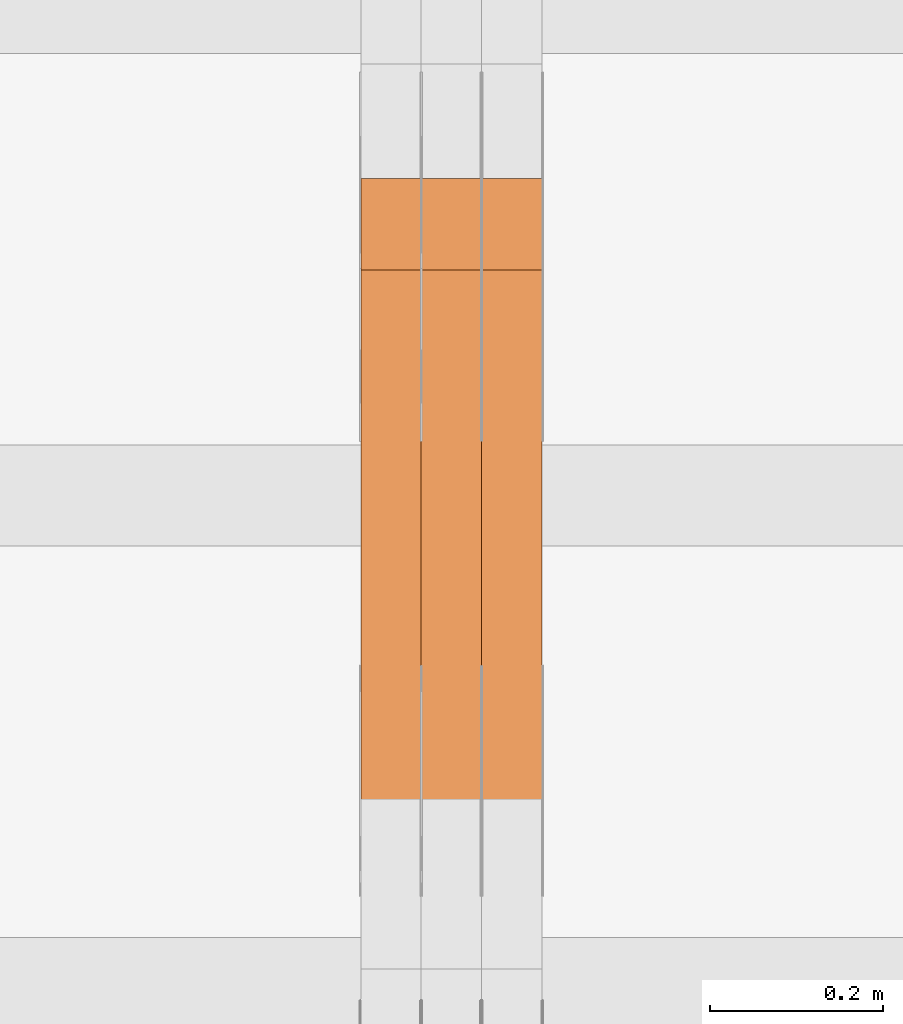
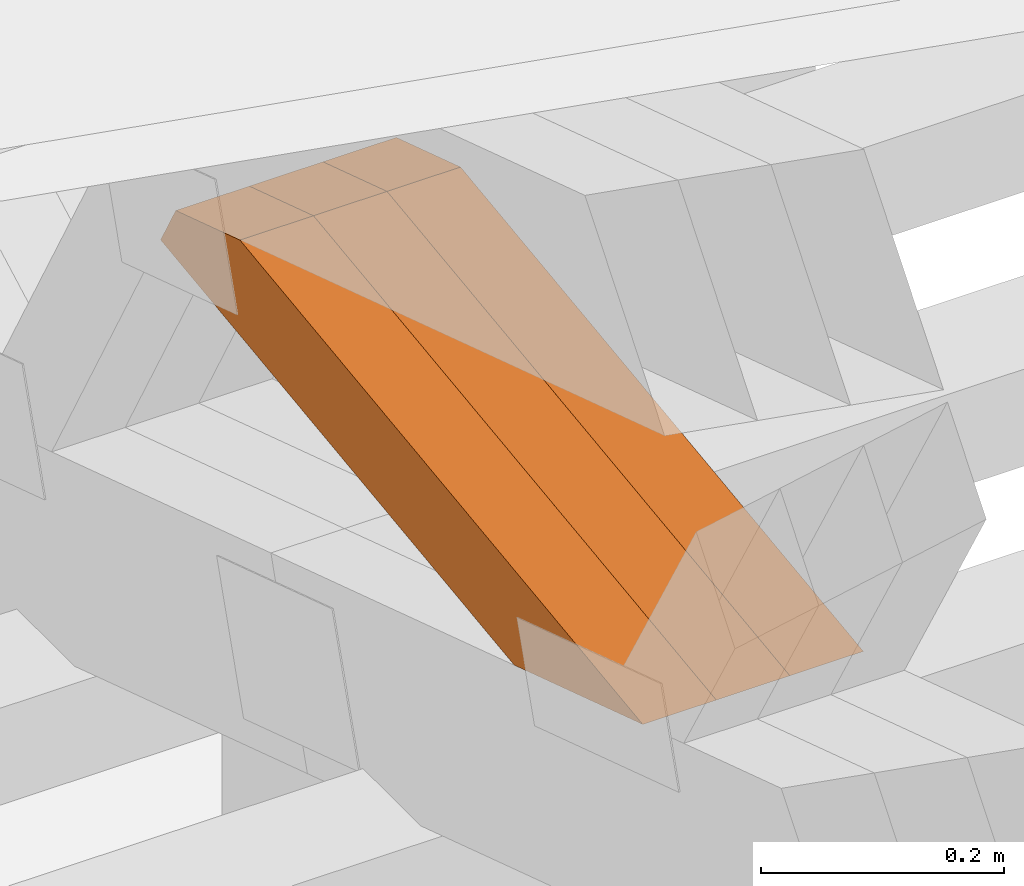
# One storey, part 305 of 385: 3 proxies.
"""IFC2X3 building model written with IfcOpenShell, lengths in millimetres."""

from ifc_helpers import new_model, entity, si_unit, converted_unit, derived_unit, direction, frame, origin, place, context, subcontext, project, spatial, polyline, outline, extrude, source, transform, mapped, material, type_object, type_shapes, element, save


model = new_model("IFC2X3")

# Units and contexts
model_context = context("Model", 3, precision=0.01, world=origin(), true_north=direction((6.12303176911189e-17, 1.0)))
body_context = subcontext(model_context, "Body", "Model", "MODEL_VIEW")
ifc_project = project(units=[si_unit("LENGTHUNIT", "METRE", prefix="MILLI"), si_unit("AREAUNIT", "SQUARE_METRE"), si_unit("VOLUMEUNIT", "CUBIC_METRE"), converted_unit("PLANEANGLEUNIT", "DEGREE", entity("IfcRatioMeasure", 0.0174532925199433), si_unit("PLANEANGLEUNIT", "RADIAN"), dimensions=[0, 0, 0, 0, 0, 0, 0]), si_unit("MASSUNIT", "GRAM", prefix="KILO"), derived_unit("MASSDENSITYUNIT", [(si_unit("MASSUNIT", "GRAM", prefix="KILO"), 1), (si_unit("LENGTHUNIT", "METRE"), -3)]), si_unit("TIMEUNIT", "SECOND"), si_unit("FREQUENCYUNIT", "HERTZ"), si_unit("THERMODYNAMICTEMPERATUREUNIT", "DEGREE_CELSIUS"), derived_unit("THERMALTRANSMITTANCEUNIT", [(si_unit("MASSUNIT", "GRAM", prefix="KILO"), 1), (si_unit("THERMODYNAMICTEMPERATUREUNIT", "KELVIN"), -1), (si_unit("TIMEUNIT", "SECOND"), -3)]), derived_unit("VOLUMETRICFLOWRATEUNIT", [(si_unit("LENGTHUNIT", "METRE"), 3), (si_unit("TIMEUNIT", "SECOND"), -1)]), si_unit("ELECTRICCURRENTUNIT", "AMPERE"), si_unit("ELECTRICVOLTAGEUNIT", "VOLT"), si_unit("POWERUNIT", "WATT"), si_unit("FORCEUNIT", "NEWTON", prefix="KILO"), si_unit("ILLUMINANCEUNIT", "LUX"), si_unit("LUMINOUSFLUXUNIT", "LUMEN"), si_unit("LUMINOUSINTENSITYUNIT", "CANDELA"), derived_unit("USERDEFINED", [(si_unit("MASSUNIT", "GRAM", prefix="KILO"), -1), (si_unit("LENGTHUNIT", "METRE"), -2), (si_unit("TIMEUNIT", "SECOND"), 3), (si_unit("LUMINOUSFLUXUNIT", "LUMEN"), 1)]), derived_unit("LINEARVELOCITYUNIT", [(si_unit("LENGTHUNIT", "METRE"), 1), (si_unit("TIMEUNIT", "SECOND"), -1)]), si_unit("PRESSUREUNIT", "PASCAL"), derived_unit("USERDEFINED", [(si_unit("LENGTHUNIT", "METRE"), -2), (si_unit("MASSUNIT", "GRAM", prefix="KILO"), 1), (si_unit("TIMEUNIT", "SECOND"), -2)])], contexts=[model_context])

# Site, building, storey
site_placement = place(None, origin())
site = spatial("IfcSite", under=ifc_project, at=site_placement, CompositionType="ELEMENT")
building_placement = place(site_placement, origin())
building = spatial("IfcBuilding", under=site, at=building_placement, CompositionType="ELEMENT")
storey_placement = place(building_placement, origin())
storey = spatial("IfcBuildingStorey", under=building, at=storey_placement, Name="Default", CompositionType="ELEMENT", Elevation=0.0)

# Proxies
ifc_material_1 = material(Name="IfcSurfaceStyle #532310")
building_element_proxy_type_1 = type_object("IfcBuildingElementProxyType", Name="T1-W6 532308", PredefinedType="NOTDEFINED", material=ifc_material_1)
shared_shape_1 = source(origin(), body_context, "Body", "SweptSolid", [
    extrude(outline(polyline([(-485.945461934772, -47.500204767976), (183.41906495488, -47.500204767976), (284.061400026172, 0.000179660053988773), (303.127757064591, 47.500114937949), (-284.66276011087, 47.500114937949), (-485.945461934772, -47.500204767976)])), frame((303.127970456024, 47.5001450766485, 0.0), z_axis=(0.0, 0.0, 1.0), x_axis=(-1.0, 0.0, 0.0)), (0.0, 0.0, 1.0), 70.0),
])
type_shapes(building_element_proxy_type_1, [shared_shape_1])
proxy_1_placement = place(building_placement, frame((45385.0, 19075.4826373647, 2770.72729201433), z_axis=(-1.0, 0.0, 0.0), x_axis=(0.0, -0.991969529622927, -0.126477082112413)))
element("IfcBuildingElementProxy", 1, at=proxy_1_placement, inside=storey, type_object=building_element_proxy_type_1, material=ifc_material_1, Name="T1-W6", context=body_context, shape_type="MappedRepresentation", body=[
    mapped(shared_shape_1, transform((0.0, 0.0, 0.0), scale=1.0)),
])
ifc_material_2 = material(Name="IfcSurfaceStyle #532244")
building_element_proxy_type_2 = type_object("IfcBuildingElementProxyType", Name="T1-W6 532242", PredefinedType="NOTDEFINED", material=ifc_material_2)
shared_shape_2 = source(origin(), body_context, "Body", "SweptSolid", [
    extrude(outline(polyline([(-485.945461934772, -47.500204767976), (183.41906495488, -47.500204767976), (284.061400026172, 0.000179660053988773), (303.127757064591, 47.500114937949), (-284.66276011087, 47.500114937949), (-485.945461934772, -47.500204767976)])), frame((303.127970456024, 47.5001450766485, 0.0), z_axis=(0.0, 0.0, 1.0), x_axis=(-1.0, 0.0, 0.0)), (0.0, 0.0, 1.0), 70.0),
])
type_shapes(building_element_proxy_type_2, [shared_shape_2])
proxy_2_placement = place(building_placement, frame((45315.0, 19075.4826373647, 2770.72729201433), z_axis=(-1.0, 0.0, 0.0), x_axis=(0.0, -0.991969529622927, -0.126477082112413)))
element("IfcBuildingElementProxy", 2, at=proxy_2_placement, inside=storey, type_object=building_element_proxy_type_2, material=ifc_material_2, Name="T1-W6", context=body_context, shape_type="MappedRepresentation", body=[
    mapped(shared_shape_2, transform((0.0, 0.0, 0.0), scale=1.0)),
])
ifc_material_3 = material(Name="IfcSurfaceStyle #532178")
building_element_proxy_type_3 = type_object("IfcBuildingElementProxyType", Name="T1-W6 532176", PredefinedType="NOTDEFINED", material=ifc_material_3)
shared_shape_3 = source(origin(), body_context, "Body", "SweptSolid", [
    extrude(outline(polyline([(-485.945461934772, -47.500204767976), (183.41906495488, -47.500204767976), (284.061400026172, 0.000179660053988773), (303.127757064591, 47.500114937949), (-284.66276011087, 47.500114937949), (-485.945461934772, -47.500204767976)])), frame((303.127970456024, 47.5001450766485, 0.0), z_axis=(0.0, 0.0, 1.0), x_axis=(-1.0, 0.0, 0.0)), (0.0, 0.0, 1.0), 70.0),
])
type_shapes(building_element_proxy_type_3, [shared_shape_3])
proxy_3_placement = place(building_placement, frame((45245.0, 19075.4826373647, 2770.72729201433), z_axis=(-1.0, 0.0, 0.0), x_axis=(0.0, -0.991969529622927, -0.126477082112413)))
element("IfcBuildingElementProxy", 3, at=proxy_3_placement, inside=storey, type_object=building_element_proxy_type_3, material=ifc_material_3, Name="T1-W6", context=body_context, shape_type="MappedRepresentation", body=[
    mapped(shared_shape_3, transform((0.0, 0.0, 0.0), scale=1.0)),
])

save(model, "model.ifc")
